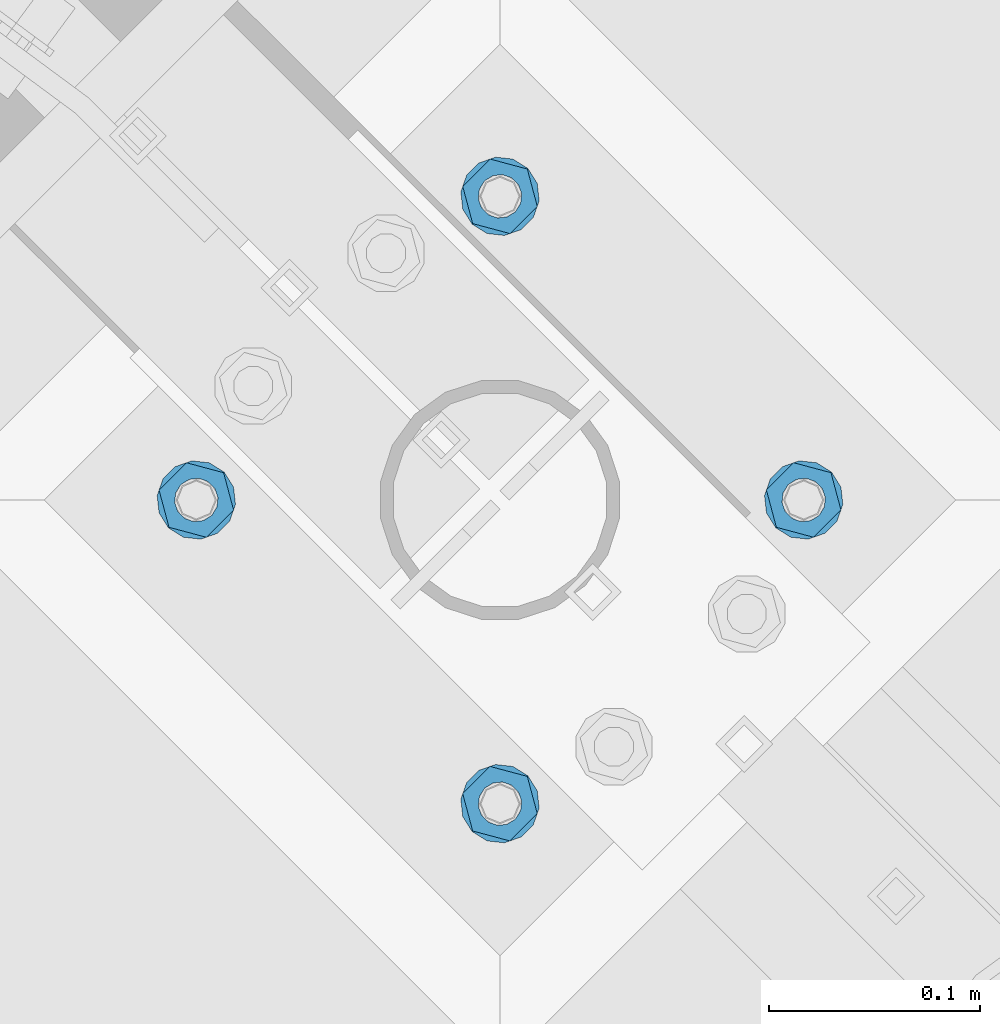
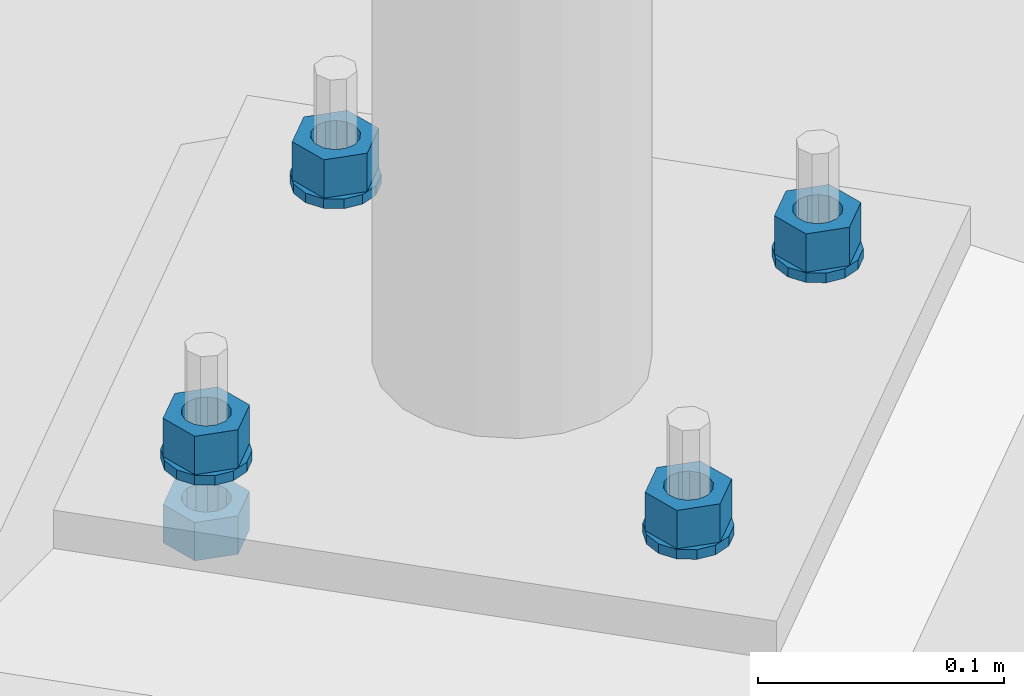
# One storey, part 635 of 975: 9 beams.
"""IFC2X3 building model written with IfcOpenShell, lengths in millimetres."""

from ifc_helpers import new_model, si_unit, frame, origin_with_axes, place, context, subcontext, project, spatial, faceted_brep, material, type_object, element, save


model = new_model("IFC2X3")

# Units and contexts
model_context = context("Model", 3, precision=1e-05, world=origin_with_axes())
body_context = subcontext(model_context, "Body", "Model", "MODEL_VIEW")
ifc_project = project(units=[si_unit("LENGTHUNIT", "METRE", prefix="MILLI"), si_unit("AREAUNIT", "SQUARE_METRE"), si_unit("VOLUMEUNIT", "CUBIC_METRE"), si_unit("MASSUNIT", "GRAM", prefix="KILO"), si_unit("TIMEUNIT", "SECOND"), si_unit("PLANEANGLEUNIT", "RADIAN"), si_unit("SOLIDANGLEUNIT", "STERADIAN"), si_unit("THERMODYNAMICTEMPERATUREUNIT", "DEGREE_CELSIUS"), si_unit("LUMINOUSINTENSITYUNIT", "LUMEN")], contexts=[model_context])

# Site, building, storey
site_placement = place(None, origin_with_axes())
site = spatial("IfcSite", under=ifc_project, at=site_placement, CompositionType="ELEMENT")
building_placement = place(site_placement, origin_with_axes())
building = spatial("IfcBuilding", under=site, at=building_placement, Name="Undefined", CompositionType="ELEMENT")
storey_placement = place(building_placement, origin_with_axes())
storey = spatial("IfcBuildingStorey", under=building, at=storey_placement, Name="Undefined", CompositionType="ELEMENT", Elevation=0.0)

# Beams
ifc_material = material(Name="STEEL/A36")
beam_type_1 = type_object("IfcBeamType", Name="3/4_WASHER", PredefinedType="NOTDEFINED")
beam_1_placement = place(storey_placement, frame((20731.162498921, 27759.8034053001, -242.8875), z_axis=(0.707106781186513, -0.707106781186582, 3.1377567211166e-14), x_axis=(0.0, 0.0, -1.0)))
element("IfcBeam", 1, at=beam_1_placement, inside=storey, type_object=beam_type_1, material=ifc_material, Name="WASHER", ObjectType="3/4_WASHER", context=body_context, shape_type="Brep", body=[
    faceted_brep([(0.0, -18.6499996185303, 0.0), (0.0, -16.8030690426876, -8.09193156902904), (4.76250000000073, -16.8030690426876, -8.09193156902904), (4.76250000000073, -18.6499996185303, 0.0), (0.0, -11.6280845668225, -14.5811568497838), (4.76250000000073, -11.6280845668225, -14.5811568497838), (0.0, -4.15001533340001, -18.1824051902857), (4.76250000000073, -4.15001533340001, -18.1824051902857), (0.0, 4.15001533340001, -18.1824051902857), (4.76250000000073, 4.15001533340001, -18.1824051902857), (0.0, 11.6280845668234, -14.5811568497838), (4.76250000000073, 11.6280845668234, -14.5811568497838), (0.0, 16.8030690426876, -8.09193156902904), (4.76250000000073, 16.8030690426876, -8.09193156902904), (0.0, 18.6499996185303, 0.0), (4.76250000000073, 18.6499996185303, 0.0), (0.0, 16.8030690426876, 8.09193156902904), (4.76250000000073, 16.8030690426876, 8.09193156902904), (0.0, 11.6280845668225, 14.5811568497838), (4.76250000000073, 11.6280845668225, 14.5811568497838), (0.0, 4.15001533340001, 18.1824051902857), (4.76250000000073, 4.15001533340001, 18.1824051902857), (0.0, -4.15001533340001, 18.1824051902857), (4.76250000000073, -4.15001533340001, 18.1824051902857), (0.0, -11.6280845668234, 14.5811568497838), (4.76250000000073, -11.6280845668234, 14.5811568497838), (0.0, -16.8030690426876, 8.09193156902904), (4.76250000000073, -16.8030690426876, 8.09193156902904), (0.0, 0.0, 10.3199996948242), (0.0, 4.47768005528269, 9.29799844179911), (4.76250000000073, 4.47768005528269, 9.29799844179911), (4.76250000000073, 0.0, 10.3199996948242), (0.0, 8.06850066047446, 6.43441456490817), (4.76250000000073, 8.06850066047446, 6.43441456490817), (0.0, 10.0612557561917, 2.29641597052117), (4.76250000000073, 10.0612557561917, 2.29641597052117), (0.0, 10.0612557561917, -2.29641597052117), (4.76250000000073, 10.0612557561917, -2.29641597052117), (0.0, 8.06850066047446, -6.43441456490814), (4.76250000000073, 8.06850066047446, -6.43441456490814), (0.0, 4.47768005528269, -9.29799844179908), (4.76250000000073, 4.47768005528269, -9.29799844179908), (0.0, 0.0, -10.3199996948242), (4.76250000000073, 0.0, -10.3199996948242), (0.0, -4.47768005528269, -9.29799844179911), (4.76250000000073, -4.47768005528269, -9.29799844179911), (0.0, -8.06850066047446, -6.43441456490817), (4.76250000000073, -8.06850066047446, -6.43441456490817), (0.0, -10.0612557561917, -2.29641597052117), (4.76250000000073, -10.0612557561917, -2.29641597052117), (0.0, -10.0612557561917, 2.29641597052117), (4.76250000000073, -10.0612557561917, 2.29641597052117), (0.0, -8.06850066047446, 6.43441456490814), (4.76250000000073, -8.06850066047446, 6.43441456490814), (0.0, -4.47768005528269, 9.29799844179908), (4.76250000000073, -4.47768005528269, 9.29799844179908)], [[[0, 1, 2, 3]], [[1, 4, 5, 2]], [[4, 6, 7, 5]], [[6, 8, 9, 7]], [[8, 10, 11, 9]], [[10, 12, 13, 11]], [[12, 14, 15, 13]], [[14, 16, 17, 15]], [[16, 18, 19, 17]], [[18, 20, 21, 19]], [[20, 22, 23, 21]], [[22, 24, 25, 23]], [[24, 26, 27, 25]], [[26, 0, 3, 27]], [[28, 29, 30, 31]], [[29, 32, 33, 30]], [[32, 34, 35, 33]], [[34, 36, 37, 35]], [[36, 38, 39, 37]], [[38, 40, 41, 39]], [[40, 42, 43, 41]], [[42, 44, 45, 43]], [[44, 46, 47, 45]], [[46, 48, 49, 47]], [[48, 50, 51, 49]], [[50, 52, 53, 51]], [[52, 54, 55, 53]], [[54, 28, 31, 55]], [[5, 7, 9, 11, 13, 15, 17, 19, 21, 23, 25, 27, 3, 2], [33, 35, 37, 39, 41, 43, 45, 47, 49, 51, 53, 55, 31, 30]], [[26, 24, 22, 20, 18, 16, 14, 12, 10, 8, 6, 4, 1, 0], [54, 52, 50, 48, 46, 44, 42, 40, 38, 36, 34, 32, 29, 28]]]),
])
beam_2_placement = place(storey_placement, frame((20874.8465946999, 27903.487501079, -242.8875), z_axis=(-0.707106781186601, 0.707106781186494, 2.36468622460961e-14), x_axis=(0.0, 0.0, -1.0)))
element("IfcBeam", 2, at=beam_2_placement, inside=storey, type_object=beam_type_1, material=ifc_material, Name="WASHER", ObjectType="3/4_WASHER", context=body_context, shape_type="Brep", body=[
    faceted_brep([(0.0, -18.6499996185303, 0.0), (0.0, -16.8030690426876, -8.09193156902904), (4.76250000000073, -16.8030690426876, -8.09193156902904), (4.76250000000073, -18.6499996185303, 0.0), (0.0, -11.6280845668225, -14.5811568497838), (4.76250000000073, -11.6280845668225, -14.5811568497838), (0.0, -4.15001533340001, -18.1824051902857), (4.76250000000073, -4.15001533340001, -18.1824051902857), (0.0, 4.15001533340001, -18.1824051902857), (4.76250000000073, 4.15001533340001, -18.1824051902857), (0.0, 11.6280845668234, -14.5811568497838), (4.76250000000073, 11.6280845668234, -14.5811568497838), (0.0, 16.8030690426876, -8.09193156902904), (4.76250000000073, 16.8030690426876, -8.09193156902904), (0.0, 18.6499996185303, 0.0), (4.76250000000073, 18.6499996185303, 0.0), (0.0, 16.8030690426876, 8.09193156902904), (4.76250000000073, 16.8030690426876, 8.09193156902904), (0.0, 11.6280845668225, 14.5811568497838), (4.76250000000073, 11.6280845668225, 14.5811568497838), (0.0, 4.15001533340001, 18.1824051902857), (4.76250000000073, 4.15001533340001, 18.1824051902857), (0.0, -4.15001533340001, 18.1824051902857), (4.76250000000073, -4.15001533340001, 18.1824051902857), (0.0, -11.6280845668234, 14.5811568497838), (4.76250000000073, -11.6280845668234, 14.5811568497838), (0.0, -16.8030690426876, 8.09193156902904), (4.76250000000073, -16.8030690426876, 8.09193156902904), (0.0, 0.0, 10.3199996948242), (0.0, 4.47768005528269, 9.29799844179911), (4.76250000000073, 4.47768005528269, 9.29799844179911), (4.76250000000073, 0.0, 10.3199996948242), (0.0, 8.06850066047446, 6.43441456490817), (4.76250000000073, 8.06850066047446, 6.43441456490817), (0.0, 10.0612557561917, 2.29641597052117), (4.76250000000073, 10.0612557561917, 2.29641597052117), (0.0, 10.0612557561917, -2.29641597052117), (4.76250000000073, 10.0612557561917, -2.29641597052117), (0.0, 8.06850066047446, -6.43441456490814), (4.76250000000073, 8.06850066047446, -6.43441456490814), (0.0, 4.47768005528269, -9.29799844179908), (4.76250000000073, 4.47768005528269, -9.29799844179908), (0.0, 0.0, -10.3199996948242), (4.76250000000073, 0.0, -10.3199996948242), (0.0, -4.47768005528269, -9.29799844179911), (4.76250000000073, -4.47768005528269, -9.29799844179911), (0.0, -8.06850066047446, -6.43441456490817), (4.76250000000073, -8.06850066047446, -6.43441456490817), (0.0, -10.0612557561917, -2.29641597052117), (4.76250000000073, -10.0612557561917, -2.29641597052117), (0.0, -10.0612557561917, 2.29641597052117), (4.76250000000073, -10.0612557561917, 2.29641597052117), (0.0, -8.06850066047446, 6.43441456490814), (4.76250000000073, -8.06850066047446, 6.43441456490814), (0.0, -4.47768005528269, 9.29799844179908), (4.76250000000073, -4.47768005528269, 9.29799844179908)], [[[0, 1, 2, 3]], [[1, 4, 5, 2]], [[4, 6, 7, 5]], [[6, 8, 9, 7]], [[8, 10, 11, 9]], [[10, 12, 13, 11]], [[12, 14, 15, 13]], [[14, 16, 17, 15]], [[16, 18, 19, 17]], [[18, 20, 21, 19]], [[20, 22, 23, 21]], [[22, 24, 25, 23]], [[24, 26, 27, 25]], [[26, 0, 3, 27]], [[28, 29, 30, 31]], [[29, 32, 33, 30]], [[32, 34, 35, 33]], [[34, 36, 37, 35]], [[36, 38, 39, 37]], [[38, 40, 41, 39]], [[40, 42, 43, 41]], [[42, 44, 45, 43]], [[44, 46, 47, 45]], [[46, 48, 49, 47]], [[48, 50, 51, 49]], [[50, 52, 53, 51]], [[52, 54, 55, 53]], [[54, 28, 31, 55]], [[5, 7, 9, 11, 13, 15, 17, 19, 21, 23, 25, 27, 3, 2], [33, 35, 37, 39, 41, 43, 45, 47, 49, 51, 53, 55, 31, 30]], [[26, 24, 22, 20, 18, 16, 14, 12, 10, 8, 6, 4, 1, 0], [54, 52, 50, 48, 46, 44, 42, 40, 38, 36, 34, 32, 29, 28]]]),
])
beam_3_placement = place(storey_placement, frame((20587.4784031422, 27903.487501079, -242.8875), z_axis=(0.707106781186513, -0.707106781186582, 3.1377567211166e-14), x_axis=(0.0, 0.0, -1.0)))
element("IfcBeam", 3, at=beam_3_placement, inside=storey, type_object=beam_type_1, material=ifc_material, Name="WASHER", ObjectType="3/4_WASHER", context=body_context, shape_type="Brep", body=[
    faceted_brep([(0.0, -18.6499996185303, 0.0), (0.0, -16.8030690426876, -8.09193156902904), (4.76250000000073, -16.8030690426876, -8.09193156902904), (4.76250000000073, -18.6499996185303, 0.0), (0.0, -11.6280845668225, -14.5811568497838), (4.76250000000073, -11.6280845668225, -14.5811568497838), (0.0, -4.15001533340001, -18.1824051902857), (4.76250000000073, -4.15001533340001, -18.1824051902857), (0.0, 4.15001533340001, -18.1824051902857), (4.76250000000073, 4.15001533340001, -18.1824051902857), (0.0, 11.6280845668234, -14.5811568497838), (4.76250000000073, 11.6280845668234, -14.5811568497838), (0.0, 16.8030690426876, -8.09193156902904), (4.76250000000073, 16.8030690426876, -8.09193156902904), (0.0, 18.6499996185303, 0.0), (4.76250000000073, 18.6499996185303, 0.0), (0.0, 16.8030690426876, 8.09193156902904), (4.76250000000073, 16.8030690426876, 8.09193156902904), (0.0, 11.6280845668225, 14.5811568497838), (4.76250000000073, 11.6280845668225, 14.5811568497838), (0.0, 4.15001533340001, 18.1824051902857), (4.76250000000073, 4.15001533340001, 18.1824051902857), (0.0, -4.15001533340001, 18.1824051902857), (4.76250000000073, -4.15001533340001, 18.1824051902857), (0.0, -11.6280845668234, 14.5811568497838), (4.76250000000073, -11.6280845668234, 14.5811568497838), (0.0, -16.8030690426876, 8.09193156902904), (4.76250000000073, -16.8030690426876, 8.09193156902904), (0.0, 0.0, 10.3199996948242), (0.0, 4.47768005528269, 9.29799844179911), (4.76250000000073, 4.47768005528269, 9.29799844179911), (4.76250000000073, 0.0, 10.3199996948242), (0.0, 8.06850066047446, 6.43441456490817), (4.76250000000073, 8.06850066047446, 6.43441456490817), (0.0, 10.0612557561917, 2.29641597052117), (4.76250000000073, 10.0612557561917, 2.29641597052117), (0.0, 10.0612557561917, -2.29641597052117), (4.76250000000073, 10.0612557561917, -2.29641597052117), (0.0, 8.06850066047446, -6.43441456490814), (4.76250000000073, 8.06850066047446, -6.43441456490814), (0.0, 4.47768005528269, -9.29799844179908), (4.76250000000073, 4.47768005528269, -9.29799844179908), (0.0, 0.0, -10.3199996948242), (4.76250000000073, 0.0, -10.3199996948242), (0.0, -4.47768005528269, -9.29799844179911), (4.76250000000073, -4.47768005528269, -9.29799844179911), (0.0, -8.06850066047446, -6.43441456490817), (4.76250000000073, -8.06850066047446, -6.43441456490817), (0.0, -10.0612557561917, -2.29641597052117), (4.76250000000073, -10.0612557561917, -2.29641597052117), (0.0, -10.0612557561917, 2.29641597052117), (4.76250000000073, -10.0612557561917, 2.29641597052117), (0.0, -8.06850066047446, 6.43441456490814), (4.76250000000073, -8.06850066047446, 6.43441456490814), (0.0, -4.47768005528269, 9.29799844179908), (4.76250000000073, -4.47768005528269, 9.29799844179908)], [[[0, 1, 2, 3]], [[1, 4, 5, 2]], [[4, 6, 7, 5]], [[6, 8, 9, 7]], [[8, 10, 11, 9]], [[10, 12, 13, 11]], [[12, 14, 15, 13]], [[14, 16, 17, 15]], [[16, 18, 19, 17]], [[18, 20, 21, 19]], [[20, 22, 23, 21]], [[22, 24, 25, 23]], [[24, 26, 27, 25]], [[26, 0, 3, 27]], [[28, 29, 30, 31]], [[29, 32, 33, 30]], [[32, 34, 35, 33]], [[34, 36, 37, 35]], [[36, 38, 39, 37]], [[38, 40, 41, 39]], [[40, 42, 43, 41]], [[42, 44, 45, 43]], [[44, 46, 47, 45]], [[46, 48, 49, 47]], [[48, 50, 51, 49]], [[50, 52, 53, 51]], [[52, 54, 55, 53]], [[54, 28, 31, 55]], [[5, 7, 9, 11, 13, 15, 17, 19, 21, 23, 25, 27, 3, 2], [33, 35, 37, 39, 41, 43, 45, 47, 49, 51, 53, 55, 31, 30]], [[26, 24, 22, 20, 18, 16, 14, 12, 10, 8, 6, 4, 1, 0], [54, 52, 50, 48, 46, 44, 42, 40, 38, 36, 34, 32, 29, 28]]]),
])
beam_4_placement = place(storey_placement, frame((20731.162498921, 28047.1715968578, -242.8875), z_axis=(-0.707106781186601, 0.707106781186494, 2.36468622460961e-14), x_axis=(0.0, 0.0, -1.0)))
element("IfcBeam", 4, at=beam_4_placement, inside=storey, type_object=beam_type_1, material=ifc_material, Name="WASHER", ObjectType="3/4_WASHER", context=body_context, shape_type="Brep", body=[
    faceted_brep([(0.0, -18.6499996185303, 0.0), (0.0, -16.8030690426876, -8.09193156902904), (4.76250000000073, -16.8030690426876, -8.09193156902904), (4.76250000000073, -18.6499996185303, 0.0), (0.0, -11.6280845668225, -14.5811568497838), (4.76250000000073, -11.6280845668225, -14.5811568497838), (0.0, -4.15001533340001, -18.1824051902857), (4.76250000000073, -4.15001533340001, -18.1824051902857), (0.0, 4.15001533340001, -18.1824051902857), (4.76250000000073, 4.15001533340001, -18.1824051902857), (0.0, 11.6280845668234, -14.5811568497838), (4.76250000000073, 11.6280845668234, -14.5811568497838), (0.0, 16.8030690426876, -8.09193156902904), (4.76250000000073, 16.8030690426876, -8.09193156902904), (0.0, 18.6499996185303, 0.0), (4.76250000000073, 18.6499996185303, 0.0), (0.0, 16.8030690426876, 8.09193156902904), (4.76250000000073, 16.8030690426876, 8.09193156902904), (0.0, 11.6280845668225, 14.5811568497838), (4.76250000000073, 11.6280845668225, 14.5811568497838), (0.0, 4.15001533340001, 18.1824051902857), (4.76250000000073, 4.15001533340001, 18.1824051902857), (0.0, -4.15001533340001, 18.1824051902857), (4.76250000000073, -4.15001533340001, 18.1824051902857), (0.0, -11.6280845668234, 14.5811568497838), (4.76250000000073, -11.6280845668234, 14.5811568497838), (0.0, -16.8030690426876, 8.09193156902904), (4.76250000000073, -16.8030690426876, 8.09193156902904), (0.0, 0.0, 10.3199996948242), (0.0, 4.47768005528269, 9.29799844179911), (4.76250000000073, 4.47768005528269, 9.29799844179911), (4.76250000000073, 0.0, 10.3199996948242), (0.0, 8.06850066047446, 6.43441456490817), (4.76250000000073, 8.06850066047446, 6.43441456490817), (0.0, 10.0612557561917, 2.29641597052117), (4.76250000000073, 10.0612557561917, 2.29641597052117), (0.0, 10.0612557561917, -2.29641597052117), (4.76250000000073, 10.0612557561917, -2.29641597052117), (0.0, 8.06850066047446, -6.43441456490814), (4.76250000000073, 8.06850066047446, -6.43441456490814), (0.0, 4.47768005528269, -9.29799844179908), (4.76250000000073, 4.47768005528269, -9.29799844179908), (0.0, 0.0, -10.3199996948242), (4.76250000000073, 0.0, -10.3199996948242), (0.0, -4.47768005528269, -9.29799844179911), (4.76250000000073, -4.47768005528269, -9.29799844179911), (0.0, -8.06850066047446, -6.43441456490817), (4.76250000000073, -8.06850066047446, -6.43441456490817), (0.0, -10.0612557561917, -2.29641597052117), (4.76250000000073, -10.0612557561917, -2.29641597052117), (0.0, -10.0612557561917, 2.29641597052117), (4.76250000000073, -10.0612557561917, 2.29641597052117), (0.0, -8.06850066047446, 6.43441456490814), (4.76250000000073, -8.06850066047446, 6.43441456490814), (0.0, -4.47768005528269, 9.29799844179908), (4.76250000000073, -4.47768005528269, 9.29799844179908)], [[[0, 1, 2, 3]], [[1, 4, 5, 2]], [[4, 6, 7, 5]], [[6, 8, 9, 7]], [[8, 10, 11, 9]], [[10, 12, 13, 11]], [[12, 14, 15, 13]], [[14, 16, 17, 15]], [[16, 18, 19, 17]], [[18, 20, 21, 19]], [[20, 22, 23, 21]], [[22, 24, 25, 23]], [[24, 26, 27, 25]], [[26, 0, 3, 27]], [[28, 29, 30, 31]], [[29, 32, 33, 30]], [[32, 34, 35, 33]], [[34, 36, 37, 35]], [[36, 38, 39, 37]], [[38, 40, 41, 39]], [[40, 42, 43, 41]], [[42, 44, 45, 43]], [[44, 46, 47, 45]], [[46, 48, 49, 47]], [[48, 50, 51, 49]], [[50, 52, 53, 51]], [[52, 54, 55, 53]], [[54, 28, 31, 55]], [[5, 7, 9, 11, 13, 15, 17, 19, 21, 23, 25, 27, 3, 2], [33, 35, 37, 39, 41, 43, 45, 47, 49, 51, 53, 55, 31, 30]], [[26, 24, 22, 20, 18, 16, 14, 12, 10, 8, 6, 4, 1, 0], [54, 52, 50, 48, 46, 44, 42, 40, 38, 36, 34, 32, 29, 28]]]),
])
beam_type_2 = type_object("IfcBeamType", Name="3/4_HEAVY_HEX_NUT", PredefinedType="NOTDEFINED")
beam_5_placement = place(storey_placement, frame((20731.162498921, 27759.8034053001, -223.837500000001), z_axis=(0.707106781186513, -0.707106781186582, 3.1377567211166e-14), x_axis=(0.0, 0.0, -1.0)))
element("IfcBeam", 5, at=beam_5_placement, inside=storey, type_object=beam_type_2, material=ifc_material, Name="NUT", ObjectType="3/4_HEAVY_HEX_NUT", context=body_context, shape_type="Brep", body=[
    faceted_brep([(0.0, -18.2600002288818, 0.0), (0.0, -9.13000011444092, -15.8100004196167), (19.0499999999993, -9.13000011444092, -15.8100004196167), (19.0499999999993, -18.2600002288818, 0.0), (0.0, 9.13000011444092, -15.8100004196167), (19.0499999999993, 9.13000011444092, -15.8100004196167), (0.0, 18.2600002288818, 0.0), (19.0499999999993, 18.2600002288818, 0.0), (0.0, 9.13000011444092, 15.8100004196167), (19.0499999999993, 9.13000011444092, 15.8100004196167), (0.0, -9.13000011444092, 15.8100004196167), (19.0499999999993, -9.13000011444092, 15.8100004196167), (0.0, 0.0, 10.3199996948242), (0.0, 4.47768005528269, 9.29799844179911), (19.0499999999993, 4.47768005528269, 9.29799844179911), (19.0499999999993, 0.0, 10.3199996948242), (0.0, 8.06850066047446, 6.43441456490817), (19.0499999999993, 8.06850066047446, 6.43441456490817), (0.0, 10.0612557561917, 2.29641597052117), (19.0499999999993, 10.0612557561917, 2.29641597052117), (0.0, 10.0612557561917, -2.29641597052117), (19.0499999999993, 10.0612557561917, -2.29641597052117), (0.0, 8.06850066047446, -6.43441456490814), (19.0499999999993, 8.06850066047446, -6.43441456490814), (0.0, 4.47768005528269, -9.29799844179908), (19.0499999999993, 4.47768005528269, -9.29799844179908), (0.0, 0.0, -10.3199996948242), (19.0499999999993, 0.0, -10.3199996948242), (0.0, -4.47768005528269, -9.29799844179911), (19.0499999999993, -4.47768005528269, -9.29799844179911), (0.0, -8.06850066047446, -6.43441456490817), (19.0499999999993, -8.06850066047446, -6.43441456490817), (0.0, -10.0612557561917, -2.29641597052117), (19.0499999999993, -10.0612557561917, -2.29641597052117), (0.0, -10.0612557561917, 2.29641597052117), (19.0499999999993, -10.0612557561917, 2.29641597052117), (0.0, -8.06850066047446, 6.43441456490814), (19.0499999999993, -8.06850066047446, 6.43441456490814), (0.0, -4.47768005528269, 9.29799844179908), (19.0499999999993, -4.47768005528269, 9.29799844179908)], [[[0, 1, 2, 3]], [[1, 4, 5, 2]], [[4, 6, 7, 5]], [[6, 8, 9, 7]], [[8, 10, 11, 9]], [[10, 0, 3, 11]], [[12, 13, 14, 15]], [[13, 16, 17, 14]], [[16, 18, 19, 17]], [[18, 20, 21, 19]], [[20, 22, 23, 21]], [[22, 24, 25, 23]], [[24, 26, 27, 25]], [[26, 28, 29, 27]], [[28, 30, 31, 29]], [[30, 32, 33, 31]], [[32, 34, 35, 33]], [[34, 36, 37, 35]], [[36, 38, 39, 37]], [[38, 12, 15, 39]], [[5, 7, 9, 11, 3, 2], [17, 19, 21, 23, 25, 27, 29, 31, 33, 35, 37, 39, 15, 14]], [[10, 8, 6, 4, 1, 0], [38, 36, 34, 32, 30, 28, 26, 24, 22, 20, 18, 16, 13, 12]]]),
])
beam_6_placement = place(storey_placement, frame((20874.8465946999, 27903.487501079, -223.837500000001), z_axis=(-0.707106781186601, 0.707106781186494, 2.36468622460961e-14), x_axis=(0.0, 0.0, -1.0)))
element("IfcBeam", 6, at=beam_6_placement, inside=storey, type_object=beam_type_2, material=ifc_material, Name="NUT", ObjectType="3/4_HEAVY_HEX_NUT", context=body_context, shape_type="Brep", body=[
    faceted_brep([(0.0, -18.2600002288818, 0.0), (0.0, -9.13000011444092, -15.8100004196167), (19.0499999999993, -9.13000011444092, -15.8100004196167), (19.0499999999993, -18.2600002288818, 0.0), (0.0, 9.13000011444092, -15.8100004196167), (19.0499999999993, 9.13000011444092, -15.8100004196167), (0.0, 18.2600002288818, 0.0), (19.0499999999993, 18.2600002288818, 0.0), (0.0, 9.13000011444092, 15.8100004196167), (19.0499999999993, 9.13000011444092, 15.8100004196167), (0.0, -9.13000011444092, 15.8100004196167), (19.0499999999993, -9.13000011444092, 15.8100004196167), (0.0, 0.0, 10.3199996948242), (0.0, 4.47768005528269, 9.29799844179911), (19.0499999999993, 4.47768005528269, 9.29799844179911), (19.0499999999993, 0.0, 10.3199996948242), (0.0, 8.06850066047446, 6.43441456490817), (19.0499999999993, 8.06850066047446, 6.43441456490817), (0.0, 10.0612557561917, 2.29641597052117), (19.0499999999993, 10.0612557561917, 2.29641597052117), (0.0, 10.0612557561917, -2.29641597052117), (19.0499999999993, 10.0612557561917, -2.29641597052117), (0.0, 8.06850066047446, -6.43441456490814), (19.0499999999993, 8.06850066047446, -6.43441456490814), (0.0, 4.47768005528269, -9.29799844179908), (19.0499999999993, 4.47768005528269, -9.29799844179908), (0.0, 0.0, -10.3199996948242), (19.0499999999993, 0.0, -10.3199996948242), (0.0, -4.47768005528269, -9.29799844179911), (19.0499999999993, -4.47768005528269, -9.29799844179911), (0.0, -8.06850066047446, -6.43441456490817), (19.0499999999993, -8.06850066047446, -6.43441456490817), (0.0, -10.0612557561917, -2.29641597052117), (19.0499999999993, -10.0612557561917, -2.29641597052117), (0.0, -10.0612557561917, 2.29641597052117), (19.0499999999993, -10.0612557561917, 2.29641597052117), (0.0, -8.06850066047446, 6.43441456490814), (19.0499999999993, -8.06850066047446, 6.43441456490814), (0.0, -4.47768005528269, 9.29799844179908), (19.0499999999993, -4.47768005528269, 9.29799844179908)], [[[0, 1, 2, 3]], [[1, 4, 5, 2]], [[4, 6, 7, 5]], [[6, 8, 9, 7]], [[8, 10, 11, 9]], [[10, 0, 3, 11]], [[12, 13, 14, 15]], [[13, 16, 17, 14]], [[16, 18, 19, 17]], [[18, 20, 21, 19]], [[20, 22, 23, 21]], [[22, 24, 25, 23]], [[24, 26, 27, 25]], [[26, 28, 29, 27]], [[28, 30, 31, 29]], [[30, 32, 33, 31]], [[32, 34, 35, 33]], [[34, 36, 37, 35]], [[36, 38, 39, 37]], [[38, 12, 15, 39]], [[5, 7, 9, 11, 3, 2], [17, 19, 21, 23, 25, 27, 29, 31, 33, 35, 37, 39, 15, 14]], [[10, 8, 6, 4, 1, 0], [38, 36, 34, 32, 30, 28, 26, 24, 22, 20, 18, 16, 13, 12]]]),
])
beam_7_placement = place(storey_placement, frame((20587.4784031422, 27903.487501079, -223.837500000001), z_axis=(0.707106781186513, -0.707106781186582, 3.1377567211166e-14), x_axis=(0.0, 0.0, -1.0)))
element("IfcBeam", 7, at=beam_7_placement, inside=storey, type_object=beam_type_2, material=ifc_material, Name="NUT", ObjectType="3/4_HEAVY_HEX_NUT", context=body_context, shape_type="Brep", body=[
    faceted_brep([(0.0, -18.2600002288818, 0.0), (0.0, -9.13000011444092, -15.8100004196167), (19.0499999999993, -9.13000011444092, -15.8100004196167), (19.0499999999993, -18.2600002288818, 0.0), (0.0, 9.13000011444092, -15.8100004196167), (19.0499999999993, 9.13000011444092, -15.8100004196167), (0.0, 18.2600002288818, 0.0), (19.0499999999993, 18.2600002288818, 0.0), (0.0, 9.13000011444092, 15.8100004196167), (19.0499999999993, 9.13000011444092, 15.8100004196167), (0.0, -9.13000011444092, 15.8100004196167), (19.0499999999993, -9.13000011444092, 15.8100004196167), (0.0, 0.0, 10.3199996948242), (0.0, 4.47768005528269, 9.29799844179911), (19.0499999999993, 4.47768005528269, 9.29799844179911), (19.0499999999993, 0.0, 10.3199996948242), (0.0, 8.06850066047446, 6.43441456490817), (19.0499999999993, 8.06850066047446, 6.43441456490817), (0.0, 10.0612557561917, 2.29641597052117), (19.0499999999993, 10.0612557561917, 2.29641597052117), (0.0, 10.0612557561917, -2.29641597052117), (19.0499999999993, 10.0612557561917, -2.29641597052117), (0.0, 8.06850066047446, -6.43441456490814), (19.0499999999993, 8.06850066047446, -6.43441456490814), (0.0, 4.47768005528269, -9.29799844179908), (19.0499999999993, 4.47768005528269, -9.29799844179908), (0.0, 0.0, -10.3199996948242), (19.0499999999993, 0.0, -10.3199996948242), (0.0, -4.47768005528269, -9.29799844179911), (19.0499999999993, -4.47768005528269, -9.29799844179911), (0.0, -8.06850066047446, -6.43441456490817), (19.0499999999993, -8.06850066047446, -6.43441456490817), (0.0, -10.0612557561917, -2.29641597052117), (19.0499999999993, -10.0612557561917, -2.29641597052117), (0.0, -10.0612557561917, 2.29641597052117), (19.0499999999993, -10.0612557561917, 2.29641597052117), (0.0, -8.06850066047446, 6.43441456490814), (19.0499999999993, -8.06850066047446, 6.43441456490814), (0.0, -4.47768005528269, 9.29799844179908), (19.0499999999993, -4.47768005528269, 9.29799844179908)], [[[0, 1, 2, 3]], [[1, 4, 5, 2]], [[4, 6, 7, 5]], [[6, 8, 9, 7]], [[8, 10, 11, 9]], [[10, 0, 3, 11]], [[12, 13, 14, 15]], [[13, 16, 17, 14]], [[16, 18, 19, 17]], [[18, 20, 21, 19]], [[20, 22, 23, 21]], [[22, 24, 25, 23]], [[24, 26, 27, 25]], [[26, 28, 29, 27]], [[28, 30, 31, 29]], [[30, 32, 33, 31]], [[32, 34, 35, 33]], [[34, 36, 37, 35]], [[36, 38, 39, 37]], [[38, 12, 15, 39]], [[5, 7, 9, 11, 3, 2], [17, 19, 21, 23, 25, 27, 29, 31, 33, 35, 37, 39, 15, 14]], [[10, 8, 6, 4, 1, 0], [38, 36, 34, 32, 30, 28, 26, 24, 22, 20, 18, 16, 13, 12]]]),
])
beam_8_placement = place(storey_placement, frame((20731.162498921, 28047.1715968578, -223.837500000001), z_axis=(-0.707106781186601, 0.707106781186494, 2.36468622460961e-14), x_axis=(0.0, 0.0, -1.0)))
element("IfcBeam", 8, at=beam_8_placement, inside=storey, type_object=beam_type_2, material=ifc_material, Name="NUT", ObjectType="3/4_HEAVY_HEX_NUT", context=body_context, shape_type="Brep", body=[
    faceted_brep([(0.0, -18.2600002288818, 0.0), (0.0, -9.13000011444092, -15.8100004196167), (19.0499999999993, -9.13000011444092, -15.8100004196167), (19.0499999999993, -18.2600002288818, 0.0), (0.0, 9.13000011444092, -15.8100004196167), (19.0499999999993, 9.13000011444092, -15.8100004196167), (0.0, 18.2600002288818, 0.0), (19.0499999999993, 18.2600002288818, 0.0), (0.0, 9.13000011444092, 15.8100004196167), (19.0499999999993, 9.13000011444092, 15.8100004196167), (0.0, -9.13000011444092, 15.8100004196167), (19.0499999999993, -9.13000011444092, 15.8100004196167), (0.0, 0.0, 10.3199996948242), (0.0, 4.47768005528269, 9.29799844179911), (19.0499999999993, 4.47768005528269, 9.29799844179911), (19.0499999999993, 0.0, 10.3199996948242), (0.0, 8.06850066047446, 6.43441456490817), (19.0499999999993, 8.06850066047446, 6.43441456490817), (0.0, 10.0612557561917, 2.29641597052117), (19.0499999999993, 10.0612557561917, 2.29641597052117), (0.0, 10.0612557561917, -2.29641597052117), (19.0499999999993, 10.0612557561917, -2.29641597052117), (0.0, 8.06850066047446, -6.43441456490814), (19.0499999999993, 8.06850066047446, -6.43441456490814), (0.0, 4.47768005528269, -9.29799844179908), (19.0499999999993, 4.47768005528269, -9.29799844179908), (0.0, 0.0, -10.3199996948242), (19.0499999999993, 0.0, -10.3199996948242), (0.0, -4.47768005528269, -9.29799844179911), (19.0499999999993, -4.47768005528269, -9.29799844179911), (0.0, -8.06850066047446, -6.43441456490817), (19.0499999999993, -8.06850066047446, -6.43441456490817), (0.0, -10.0612557561917, -2.29641597052117), (19.0499999999993, -10.0612557561917, -2.29641597052117), (0.0, -10.0612557561917, 2.29641597052117), (19.0499999999993, -10.0612557561917, 2.29641597052117), (0.0, -8.06850066047446, 6.43441456490814), (19.0499999999993, -8.06850066047446, 6.43441456490814), (0.0, -4.47768005528269, 9.29799844179908), (19.0499999999993, -4.47768005528269, 9.29799844179908)], [[[0, 1, 2, 3]], [[1, 4, 5, 2]], [[4, 6, 7, 5]], [[6, 8, 9, 7]], [[8, 10, 11, 9]], [[10, 0, 3, 11]], [[12, 13, 14, 15]], [[13, 16, 17, 14]], [[16, 18, 19, 17]], [[18, 20, 21, 19]], [[20, 22, 23, 21]], [[22, 24, 25, 23]], [[24, 26, 27, 25]], [[26, 28, 29, 27]], [[28, 30, 31, 29]], [[30, 32, 33, 31]], [[32, 34, 35, 33]], [[34, 36, 37, 35]], [[36, 38, 39, 37]], [[38, 12, 15, 39]], [[5, 7, 9, 11, 3, 2], [17, 19, 21, 23, 25, 27, 29, 31, 33, 35, 37, 39, 15, 14]], [[10, 8, 6, 4, 1, 0], [38, 36, 34, 32, 30, 28, 26, 24, 22, 20, 18, 16, 13, 12]]]),
])
beam_9_placement = place(storey_placement, frame((20587.4784031422, 27903.487501079, -266.7), z_axis=(0.707106781186513, -0.707106781186582, 3.1377567211166e-14), x_axis=(0.0, 0.0, -1.0)))
element("IfcBeam", 9, at=beam_9_placement, inside=storey, type_object=beam_type_2, material=ifc_material, Name="NUT", ObjectType="3/4_HEAVY_HEX_NUT", context=body_context, shape_type="Brep", body=[
    faceted_brep([(0.0, -18.2600002288818, 0.0), (0.0, -9.13000011444092, -15.8100004196167), (19.0499999999993, -9.13000011444092, -15.8100004196167), (19.0499999999993, -18.2600002288818, 0.0), (0.0, 9.13000011444092, -15.8100004196167), (19.0499999999993, 9.13000011444092, -15.8100004196167), (0.0, 18.2600002288818, 0.0), (19.0499999999993, 18.2600002288818, 0.0), (0.0, 9.13000011444092, 15.8100004196167), (19.0499999999993, 9.13000011444092, 15.8100004196167), (0.0, -9.13000011444092, 15.8100004196167), (19.0499999999993, -9.13000011444092, 15.8100004196167), (0.0, 0.0, 10.3199996948242), (0.0, 4.47768005528269, 9.29799844179911), (19.0499999999993, 4.47768005528269, 9.29799844179911), (19.0499999999993, 0.0, 10.3199996948242), (0.0, 8.06850066047446, 6.43441456490817), (19.0499999999993, 8.06850066047446, 6.43441456490817), (0.0, 10.0612557561917, 2.29641597052117), (19.0499999999993, 10.0612557561917, 2.29641597052117), (0.0, 10.0612557561917, -2.29641597052117), (19.0499999999993, 10.0612557561917, -2.29641597052117), (0.0, 8.06850066047446, -6.43441456490814), (19.0499999999993, 8.06850066047446, -6.43441456490814), (0.0, 4.47768005528269, -9.29799844179908), (19.0499999999993, 4.47768005528269, -9.29799844179908), (0.0, 0.0, -10.3199996948242), (19.0499999999993, 0.0, -10.3199996948242), (0.0, -4.47768005528269, -9.29799844179911), (19.0499999999993, -4.47768005528269, -9.29799844179911), (0.0, -8.06850066047446, -6.43441456490817), (19.0499999999993, -8.06850066047446, -6.43441456490817), (0.0, -10.0612557561917, -2.29641597052117), (19.0499999999993, -10.0612557561917, -2.29641597052117), (0.0, -10.0612557561917, 2.29641597052117), (19.0499999999993, -10.0612557561917, 2.29641597052117), (0.0, -8.06850066047446, 6.43441456490814), (19.0499999999993, -8.06850066047446, 6.43441456490814), (0.0, -4.47768005528269, 9.29799844179908), (19.0499999999993, -4.47768005528269, 9.29799844179908)], [[[0, 1, 2, 3]], [[1, 4, 5, 2]], [[4, 6, 7, 5]], [[6, 8, 9, 7]], [[8, 10, 11, 9]], [[10, 0, 3, 11]], [[12, 13, 14, 15]], [[13, 16, 17, 14]], [[16, 18, 19, 17]], [[18, 20, 21, 19]], [[20, 22, 23, 21]], [[22, 24, 25, 23]], [[24, 26, 27, 25]], [[26, 28, 29, 27]], [[28, 30, 31, 29]], [[30, 32, 33, 31]], [[32, 34, 35, 33]], [[34, 36, 37, 35]], [[36, 38, 39, 37]], [[38, 12, 15, 39]], [[5, 7, 9, 11, 3, 2], [17, 19, 21, 23, 25, 27, 29, 31, 33, 35, 37, 39, 15, 14]], [[10, 8, 6, 4, 1, 0], [38, 36, 34, 32, 30, 28, 26, 24, 22, 20, 18, 16, 13, 12]]]),
])

save(model, "model.ifc")
